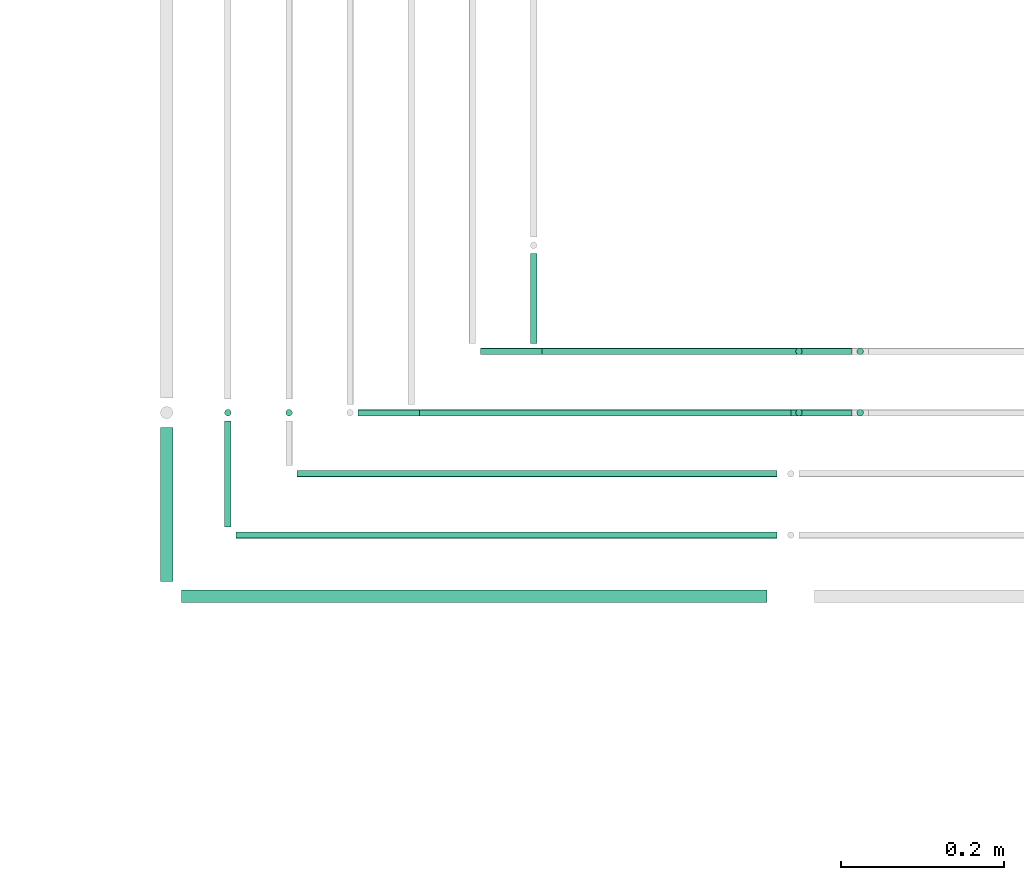
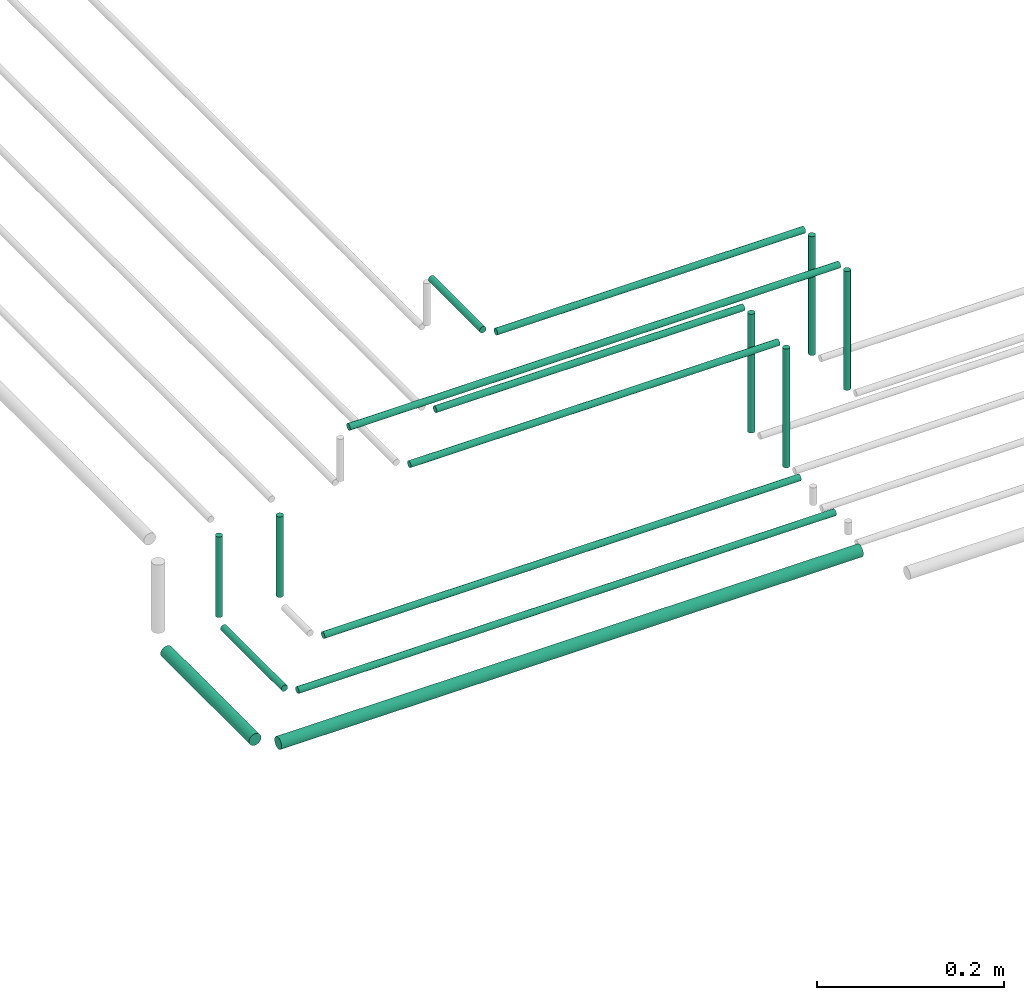
# One storey, part 57 of 89: 16 flow segments.
"""IFC2X3 building model written with IfcOpenShell, lengths in millimetres."""

from ifc_helpers import new_model, entity, si_unit, converted_unit, derived_unit, direction, frame, frame_2d, origin, origin_2d_with_axis, place, context, subcontext, project, spatial, circle, extrude, type_object, element, save


model = new_model("IFC2X3")

# Units and contexts
model_context = context("Model", 3, precision=0.01, world=origin(), true_north=direction((6.12303176911189e-17, 1.0)))
body_context = subcontext(model_context, "Body", "Model", "MODEL_VIEW")
ifc_project = project(units=[si_unit("LENGTHUNIT", "METRE", prefix="MILLI"), si_unit("AREAUNIT", "SQUARE_METRE"), si_unit("VOLUMEUNIT", "CUBIC_METRE"), converted_unit("PLANEANGLEUNIT", "DEGREE", entity("IfcRatioMeasure", 0.0174532925199433), si_unit("PLANEANGLEUNIT", "RADIAN"), dimensions=[0, 0, 0, 0, 0, 0, 0]), si_unit("MASSUNIT", "GRAM", prefix="KILO"), derived_unit("MASSDENSITYUNIT", [(si_unit("MASSUNIT", "GRAM", prefix="KILO"), 1), (si_unit("LENGTHUNIT", "METRE"), -3)]), derived_unit("MOMENTOFINERTIAUNIT", [(si_unit("LENGTHUNIT", "METRE"), 4)]), si_unit("TIMEUNIT", "SECOND"), si_unit("FREQUENCYUNIT", "HERTZ"), si_unit("THERMODYNAMICTEMPERATUREUNIT", "DEGREE_CELSIUS"), derived_unit("THERMALTRANSMITTANCEUNIT", [(si_unit("MASSUNIT", "GRAM", prefix="KILO"), 1), (si_unit("THERMODYNAMICTEMPERATUREUNIT", "KELVIN"), -1), (si_unit("TIMEUNIT", "SECOND"), -3)]), derived_unit("VOLUMETRICFLOWRATEUNIT", [(si_unit("LENGTHUNIT", "METRE"), 3), (si_unit("TIMEUNIT", "SECOND"), -1)]), derived_unit("MASSFLOWRATEUNIT", [(si_unit("MASSUNIT", "GRAM", prefix="KILO"), 1), (si_unit("TIMEUNIT", "SECOND"), -1)]), derived_unit("ROTATIONALFREQUENCYUNIT", [(si_unit("TIMEUNIT", "SECOND"), -1)]), si_unit("ELECTRICCURRENTUNIT", "AMPERE"), si_unit("ELECTRICVOLTAGEUNIT", "VOLT"), si_unit("POWERUNIT", "WATT"), si_unit("FORCEUNIT", "NEWTON", prefix="KILO"), si_unit("ILLUMINANCEUNIT", "LUX"), si_unit("LUMINOUSFLUXUNIT", "LUMEN"), si_unit("LUMINOUSINTENSITYUNIT", "CANDELA"), derived_unit("USERDEFINED", [(si_unit("MASSUNIT", "GRAM", prefix="KILO"), -1), (si_unit("LENGTHUNIT", "METRE"), -2), (si_unit("TIMEUNIT", "SECOND"), 3), (si_unit("LUMINOUSFLUXUNIT", "LUMEN"), 1)]), derived_unit("LINEARVELOCITYUNIT", [(si_unit("LENGTHUNIT", "METRE"), 1), (si_unit("TIMEUNIT", "SECOND"), -1)]), si_unit("PRESSUREUNIT", "PASCAL"), derived_unit("USERDEFINED", [(si_unit("LENGTHUNIT", "METRE"), -2), (si_unit("MASSUNIT", "GRAM", prefix="KILO"), 1), (si_unit("TIMEUNIT", "SECOND"), -2)]), derived_unit("LINEARFORCEUNIT", [(si_unit("MASSUNIT", "GRAM", prefix="KILO"), 1), (si_unit("LENGTHUNIT", "METRE"), 1), (si_unit("TIMEUNIT", "SECOND"), -2), (si_unit("LENGTHUNIT", "METRE"), -1)]), derived_unit("PLANARFORCEUNIT", [(si_unit("MASSUNIT", "GRAM", prefix="KILO"), 1), (si_unit("LENGTHUNIT", "METRE"), 1), (si_unit("TIMEUNIT", "SECOND"), -2), (si_unit("LENGTHUNIT", "METRE"), -2)])], contexts=[model_context])

# Site, building, storey
site_placement = place(None, frame((0.0, -0.00077364408347762, 0.0)))
site = spatial("IfcSite", under=ifc_project, at=site_placement, CompositionType="ELEMENT")
building_placement = place(site_placement, origin())
building = spatial("IfcBuilding", under=site, at=building_placement, CompositionType="ELEMENT")
storey_placement = place(building_placement, frame((0.0, 0.0, 24000.0)))
storey = spatial("IfcBuildingStorey", under=building, at=storey_placement, CompositionType="ELEMENT", Elevation=24000.0)

# Flow segments
pipe_segment_type = type_object("IfcPipeSegmentType", PredefinedType="NOTDEFINED")
flow_segment_1_placement = place(storey_placement, frame((64700.0850909111, 10194.4047277637, 2719.40472776409)))
element("IfcFlowSegment", 1, at=flow_segment_1_placement, inside=storey, type_object=pipe_segment_type, context=body_context, shape_type="SweptSolid", body=[
    extrude(circle(Radius=4.0, at=origin_2d_with_axis()), frame((0.0, 5.59527223591282, 5.59527223591499), z_axis=(1.0, 0.0, 0.0), x_axis=(0.0, -1.0, 0.0)), (0.0, 0.0, 1.0), 587.945145631458),
])
flow_segment_2_placement = place(storey_placement, frame((64625.0850909111, 10119.4047277637, 2719.40472776408)))
element("IfcFlowSegment", 2, at=flow_segment_2_placement, inside=storey, type_object=pipe_segment_type, context=body_context, shape_type="SweptSolid", body=[
    extrude(circle(Radius=4.0, at=origin_2d_with_axis()), frame((0.0, 5.59527223591499, 5.59527223591499), z_axis=(1.0, 0.0, 0.0), x_axis=(0.0, -1.0, 0.0)), (0.0, 0.0, 1.0), 662.945145631459),
])
flow_segment_3_placement = place(storey_placement, frame((64558.0850909111, 10040.9047277637, 2715.90472776406)))
element("IfcFlowSegment", 3, at=flow_segment_3_placement, inside=storey, type_object=pipe_segment_type, context=body_context, shape_type="SweptSolid", body=[
    extrude(circle(Radius=7.5, at=origin_2d_with_axis()), frame((0.0, 9.09527223591853, 9.09527223591419), z_axis=(1.0, 0.0, 0.0), x_axis=(0.0, -1.0, 0.0)), (0.0, 0.0, 1.0), 717.945145631455),
])
flow_segment_4_placement = place(storey_placement, frame((64530.9898186752, 10068.0, 2715.90472776406)))
element("IfcFlowSegment", 4, at=flow_segment_4_placement, inside=storey, type_object=pipe_segment_type, context=body_context, shape_type="SweptSolid", body=[
    extrude(circle(Radius=7.5, at=frame_2d((-8.66293703438714e-12, 0.0), x_axis=(1.0, 0.0))), frame((9.09527223592286, 0.0, 9.09527223591419), z_axis=(0.0, 1.0, 0.0), x_axis=(1.0, 0.0, 0.0)), (0.0, 0.0, 1.0), 189.000000000024),
])
flow_segment_5_placement = place(storey_placement, frame((64609.4898186752, 10135.0, 2719.40472776408)))
element("IfcFlowSegment", 5, at=flow_segment_5_placement, inside=storey, type_object=pipe_segment_type, context=body_context, shape_type="SweptSolid", body=[
    extrude(circle(Radius=4.0, at=origin_2d_with_axis()), frame((5.59527223591499, 0.0, 5.59527223591499), z_axis=(0.0, 1.0, 0.0), x_axis=(1.0, 0.0, 0.0)), (0.0, 0.0, 1.0), 130.000000000016),
])
flow_segment_6_placement = place(storey_placement, frame((64609.4898186752, 10269.4047277637, 2735.0)))
element("IfcFlowSegment", 6, at=flow_segment_6_placement, inside=storey, type_object=pipe_segment_type, context=body_context, shape_type="SweptSolid", body=[
    extrude(circle(Radius=4.0, at=origin_2d_with_axis()), frame((5.59527223591499, 5.59527223591499, 0.0), z_axis=(0.0, 0.0, 1.0), x_axis=(-1.0, 0.0, 0.0)), (0.0, 0.0, 1.0), 105.00000000008),
])
flow_segment_7_placement = place(storey_placement, frame((64684.4898186752, 10269.4047277637, 2735.0)))
element("IfcFlowSegment", 7, at=flow_segment_7_placement, inside=storey, type_object=pipe_segment_type, context=body_context, shape_type="SweptSolid", body=[
    extrude(circle(Radius=4.0, at=origin_2d_with_axis()), frame((5.59527223591499, 5.59527223591499, 0.0), z_axis=(0.0, 0.0, 1.0), x_axis=(-1.0, 0.0, 0.0)), (0.0, 0.0, 1.0), 105.000000000089),
])
flow_segment_8_placement = place(storey_placement, frame((64999.799693268, 10344.4047277637, 2919.40472776409)))
element("IfcFlowSegment", 8, at=flow_segment_8_placement, inside=storey, type_object=pipe_segment_type, context=body_context, shape_type="SweptSolid", body=[
    extrude(circle(Radius=4.0, at=origin_2d_with_axis()), frame((0.0, 5.59527223591282, 5.59527223591499), z_axis=(1.0, 0.0, 0.0), x_axis=(0.0, -1.0, 0.0)), (0.0, 0.0, 1.0), 380.230543274535),
])
flow_segment_9_placement = place(storey_placement, frame((65384.4349643066, 10344.4047277637, 2760.0)))
element("IfcFlowSegment", 9, at=flow_segment_9_placement, inside=storey, type_object=pipe_segment_type, context=body_context, shape_type="SweptSolid", body=[
    extrude(circle(Radius=4.0, at=origin_2d_with_axis()), frame((5.59527223591499, 5.59527223591499, 0.0), z_axis=(0.0, 0.0, 1.0), x_axis=(-1.0, 0.0, 0.0)), (0.0, 0.0, 1.0), 155.000000000004),
])
flow_segment_10_placement = place(storey_placement, frame((64924.799693268, 10344.4047277637, 2844.4047277641)))
element("IfcFlowSegment", 10, at=flow_segment_10_placement, inside=storey, type_object=pipe_segment_type, context=body_context, shape_type="SweptSolid", body=[
    extrude(circle(Radius=4.0, at=frame_2d((1.51601398101775e-11, 0.0), x_axis=(1.0, 0.0))), frame((0.0, 5.59527223593232, 5.59527223591499), z_axis=(1.0, 0.0, 0.0), x_axis=(0.0, 1.0, 0.0)), (0.0, 0.0, 1.0), 380.230543274518),
])
flow_segment_11_placement = place(storey_placement, frame((65309.4349643066, 10344.4047277638, 2685.0)))
element("IfcFlowSegment", 11, at=flow_segment_11_placement, inside=storey, type_object=pipe_segment_type, context=body_context, shape_type="SweptSolid", body=[
    extrude(circle(Radius=4.0, at=origin_2d_with_axis()), frame((5.59527223591499, 5.59527223591499, 0.0), z_axis=(0.0, 0.0, 1.0), x_axis=(-1.0, 0.0, 0.0)), (0.0, 0.0, 1.0), 155.000000000025),
])
flow_segment_12_placement = place(storey_placement, frame((64849.799693268, 10269.4047277637, 2844.40472776409)))
element("IfcFlowSegment", 12, at=flow_segment_12_placement, inside=storey, type_object=pipe_segment_type, context=body_context, shape_type="SweptSolid", body=[
    extrude(circle(Radius=4.0, at=origin_2d_with_axis()), frame((0.0, 5.59527223591282, 5.59527223591499), z_axis=(1.0, 0.0, 0.0), x_axis=(0.0, -1.0, 0.0)), (0.0, 0.0, 1.0), 455.230543274535),
])
flow_segment_13_placement = place(storey_placement, frame((65309.4349643066, 10269.4047277637, 2685.0)))
element("IfcFlowSegment", 13, at=flow_segment_13_placement, inside=storey, type_object=pipe_segment_type, context=body_context, shape_type="SweptSolid", body=[
    extrude(circle(Radius=4.0, at=origin_2d_with_axis()), frame((5.59527223591499, 5.59527223591499, 0.0), z_axis=(0.0, 0.0, 1.0), x_axis=(-1.0, 0.0, 0.0)), (0.0, 0.0, 1.0), 155.000000000017),
])
flow_segment_14_placement = place(storey_placement, frame((64984.2044210321, 10360.0, 2919.4047277641)))
element("IfcFlowSegment", 14, at=flow_segment_14_placement, inside=storey, type_object=pipe_segment_type, context=body_context, shape_type="SweptSolid", body=[
    extrude(circle(Radius=4.0, at=origin_2d_with_axis()), frame((5.59527223591499, 0.0, 5.59527223591499), z_axis=(0.0, 1.0, 0.0), x_axis=(-1.0, 0.0, 0.0)), (0.0, 0.0, 1.0), 110.000000000486),
])
flow_segment_15_placement = place(storey_placement, frame((64774.799693268, 10269.4047277637, 2919.4047277641)))
element("IfcFlowSegment", 15, at=flow_segment_15_placement, inside=storey, type_object=pipe_segment_type, context=body_context, shape_type="SweptSolid", body=[
    extrude(circle(Radius=4.0, at=origin_2d_with_axis()), frame((0.0, 5.59527223592365, 5.59527223591499), z_axis=(1.0, 0.0, 0.0), x_axis=(0.0, -1.0, 0.0)), (0.0, 0.0, 1.0), 605.230543274536),
])
flow_segment_16_placement = place(storey_placement, frame((65384.4349643066, 10269.4047277637, 2760.0)))
element("IfcFlowSegment", 16, at=flow_segment_16_placement, inside=storey, type_object=pipe_segment_type, context=body_context, shape_type="SweptSolid", body=[
    extrude(circle(Radius=4.0, at=origin_2d_with_axis()), frame((5.59527223591499, 5.59527223591499, 0.0), z_axis=(0.0, 0.0, 1.0), x_axis=(-1.0, 0.0, 0.0)), (0.0, 0.0, 1.0), 155.000000000012),
])

save(model, "model.ifc")
